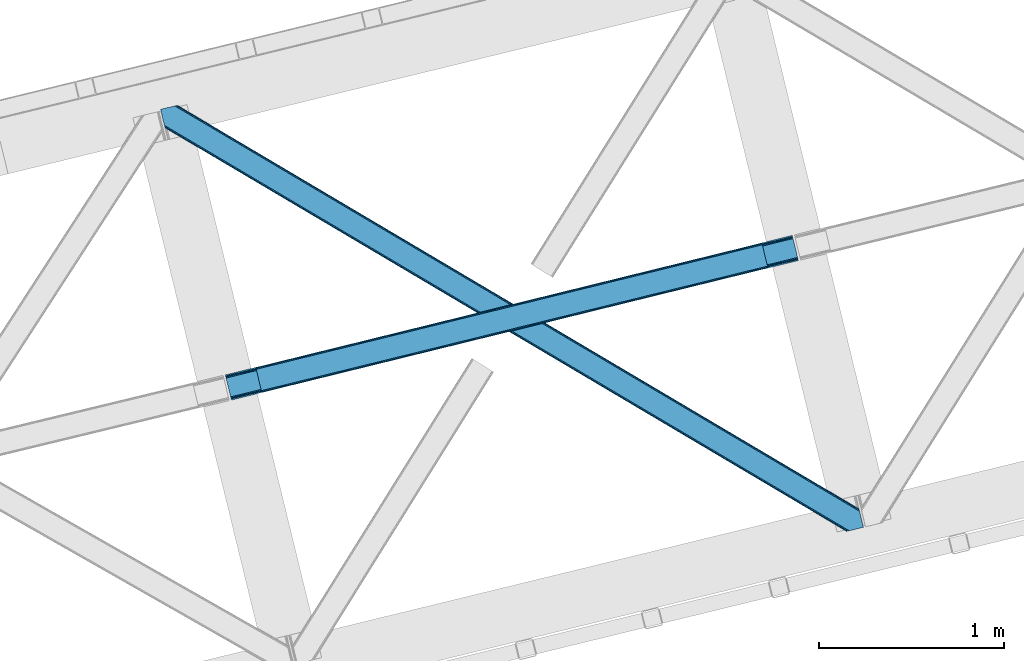
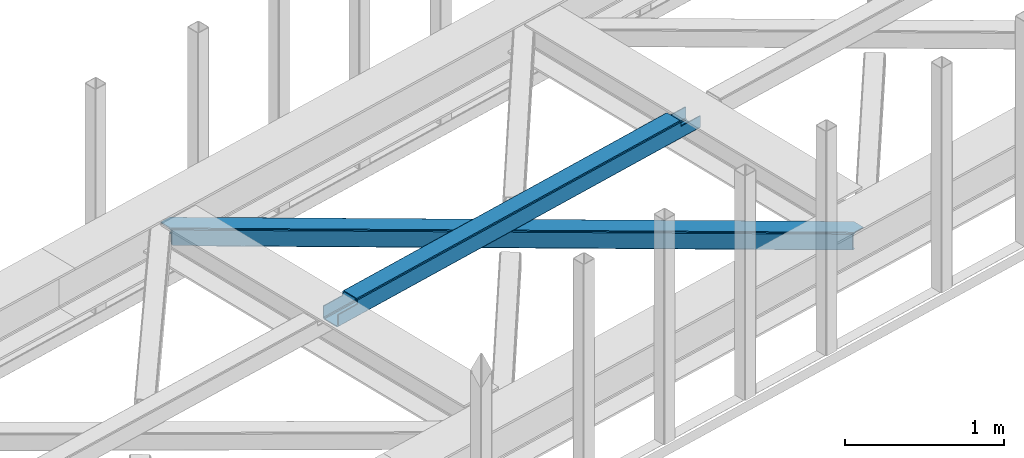
# One storey, part 39 of 67: 1 beam, 1 member.
"""IFC4 building model written with IfcOpenShell, lengths in millimetres."""

from ifc_helpers import new_model, entity, si_unit, converted_unit, derived_unit, direction, frame, origin, place, context, subcontext, project, spatial, triangles, polygons, material, type_object, element, save


model = new_model("IFC4")

# Units and contexts
model_context = context("Model", 3, precision=0.01, world=origin(), true_north=direction((6.12303176911189e-17, 1.0)))
plan_context = context("Plan", 3, precision=0.01, world=origin(), true_north=direction((6.12303176911189e-17, 1.0)))
body_context = subcontext(model_context, "Body", "Model", "MODEL_VIEW")
ifc_project = project(units=[si_unit("LENGTHUNIT", "METRE", prefix="MILLI"), si_unit("AREAUNIT", "SQUARE_METRE"), si_unit("VOLUMEUNIT", "CUBIC_METRE"), converted_unit("PLANEANGLEUNIT", "DEGREE", entity("IfcRatioMeasure", 0.0174532925199433), si_unit("PLANEANGLEUNIT", "RADIAN"), dimensions=[0, 0, 0, 0, 0, 0, 0]), si_unit("MASSUNIT", "GRAM", prefix="KILO"), derived_unit("MASSDENSITYUNIT", [(si_unit("MASSUNIT", "GRAM", prefix="KILO"), 1), (si_unit("LENGTHUNIT", "METRE"), -3)]), derived_unit("MOMENTOFINERTIAUNIT", [(si_unit("LENGTHUNIT", "METRE"), 4)]), si_unit("TIMEUNIT", "SECOND"), si_unit("FREQUENCYUNIT", "HERTZ"), si_unit("THERMODYNAMICTEMPERATUREUNIT", "DEGREE_CELSIUS"), derived_unit("THERMALTRANSMITTANCEUNIT", [(si_unit("MASSUNIT", "GRAM", prefix="KILO"), 1), (si_unit("THERMODYNAMICTEMPERATUREUNIT", "KELVIN"), -1), (si_unit("TIMEUNIT", "SECOND"), -3)]), derived_unit("VOLUMETRICFLOWRATEUNIT", [(si_unit("LENGTHUNIT", "METRE"), 3), (si_unit("TIMEUNIT", "SECOND"), -1)]), derived_unit("MASSFLOWRATEUNIT", [(si_unit("MASSUNIT", "GRAM", prefix="KILO"), 1), (si_unit("TIMEUNIT", "SECOND"), -1)]), derived_unit("ROTATIONALFREQUENCYUNIT", [(si_unit("TIMEUNIT", "SECOND"), -1)]), si_unit("ELECTRICCURRENTUNIT", "AMPERE"), si_unit("ELECTRICVOLTAGEUNIT", "VOLT"), si_unit("POWERUNIT", "WATT"), si_unit("FORCEUNIT", "NEWTON", prefix="KILO"), si_unit("ILLUMINANCEUNIT", "LUX"), si_unit("LUMINOUSFLUXUNIT", "LUMEN"), si_unit("LUMINOUSINTENSITYUNIT", "CANDELA"), derived_unit("USERDEFINED", [(si_unit("MASSUNIT", "GRAM", prefix="KILO"), -1), (si_unit("LENGTHUNIT", "METRE"), -2), (si_unit("TIMEUNIT", "SECOND"), 3), (si_unit("LUMINOUSFLUXUNIT", "LUMEN"), 1)]), derived_unit("LINEARVELOCITYUNIT", [(si_unit("LENGTHUNIT", "METRE"), 1), (si_unit("TIMEUNIT", "SECOND"), -1)]), si_unit("PRESSUREUNIT", "PASCAL"), derived_unit("USERDEFINED", [(si_unit("LENGTHUNIT", "METRE"), -2), (si_unit("MASSUNIT", "GRAM", prefix="KILO"), 1), (si_unit("TIMEUNIT", "SECOND"), -2)]), derived_unit("LINEARFORCEUNIT", [(si_unit("MASSUNIT", "GRAM", prefix="KILO"), 1), (si_unit("LENGTHUNIT", "METRE"), 1), (si_unit("TIMEUNIT", "SECOND"), -2), (si_unit("LENGTHUNIT", "METRE"), -1)]), derived_unit("PLANARFORCEUNIT", [(si_unit("MASSUNIT", "GRAM", prefix="KILO"), 1), (si_unit("LENGTHUNIT", "METRE"), 1), (si_unit("TIMEUNIT", "SECOND"), -2), (si_unit("LENGTHUNIT", "METRE"), -2)])], contexts=[model_context, plan_context])

# Site, building, storey
site_placement = place(None, origin())
site = spatial("IfcSite", under=ifc_project, at=site_placement, CompositionType="ELEMENT")
building_placement = place(site_placement, origin())
building = spatial("IfcBuilding", under=site, at=building_placement, CompositionType="ELEMENT")
storey_placement = place(building_placement, frame((0.0, 0.0, 19800.0)))
storey = spatial("IfcBuildingStorey", under=building, at=storey_placement, CompositionType="ELEMENT", Elevation=19800.0)

# Beam
ifc_material = material(Name="Metal painted (White)")
beam_type = type_object("IfcBeamType", PredefinedType="BEAM")
beam_placement = place(storey_placement, frame((-29806.6979951738, 11867.3098828586, 3967.02204271735)))
element("IfcBeam", 1, at=beam_placement, inside=storey, type_object=beam_type, material=ifc_material, ObjectType="Steel Beam", PredefinedType="BEAM", context=body_context, shape_type="Tessellation", body=[
    polygons([(195.604746583075, 47.1752169465625, 116.423738076669), (195.289267887383, 48.4694323441397, 123.120697582703), (2923.92903262095, 719.782371889898, 122.249440972472), (2924.24451131664, 718.48815649231, 115.552481466434), (194.3908605719, 52.1550459747286, 128.798103947525), (2923.03062530547, 723.467985520489, 127.926847337285), (193.04629900633, 57.6709565732295, 132.591623517896), (2921.6860637399, 728.983896118994, 131.720366907661), (191.46028050054, 64.1774167528979, 133.923727327576), (2920.10004523411, 735.490356298641, 133.052470717336), (169.909056871414, 152.588855745844, 133.923667058171), (2898.54882160498, 823.901795291585, 133.052410447936), (168.323038365632, 159.095315925473, 132.591554377688), (2896.9628030992, 830.40825547123, 131.720297767452), (166.978476800063, 164.611226523979, 128.798027287003), (2895.61824153363, 835.924166069733, 127.926770676772), (166.080069484584, 168.29684015457, 123.120615897284), (2894.71983421815, 839.609779700328, 122.24935928704), (165.764590788888, 169.591055552179, 116.423654626735), (2894.40435552246, 840.903995097923, 115.552398016495), (2892.74656908944, 847.704875020456, 100.498181174067), (2892.74656908944, 847.704875020458, 122.552393716857), (2893.06204778513, 846.410659622874, 129.249354987406), (2893.96045510062, 842.725045992283, 134.92676637713), (2895.30501666619, 837.20913539378, 138.720293467814), (2896.89103517197, 830.70267521412, 140.052406148298), (2921.75783166713, 728.689476376108, 140.052475689917), (2923.3438501729, 722.183016196485, 138.720371880237), (2924.68841173848, 716.667105597982, 134.926852309861), (2925.58681905396, 712.981491967389, 129.249445945048), (2925.90229774989, 711.687276568789, 122.55248643901), (2925.90229774965, 711.687276569775, 100.498181174067), (2924.24451131664, 718.488156492308, 100.498181174067), (2894.40435552246, 840.903995097923, 100.498181174067), (165.764590788884, 169.591055552182, 101.477957282639), (195.60474658307, 47.1752169465668, 101.477957282639), (197.262533018061, 40.37433701599, 101.477957282639), (197.262533016081, 40.3743370240292, 123.423743049245), (196.947054320385, 41.6685524216237, 130.120702555279), (196.048647004907, 45.354166052217, 135.798108920101), (194.704085439337, 50.8700766507178, 139.591628490473), (193.118066933551, 57.3765368303668, 140.923732300152), (168.251270438398, 159.389735668379, 140.923662758538), (166.665251932617, 165.896195848024, 139.59155007805), (165.320690367043, 171.412106446525, 135.798022987369), (164.422283051569, 175.097720077118, 130.120611597646), (164.106804355869, 176.391935474715, 123.423650327093), (164.106804355873, 176.391935474715, 101.477957282639), (3088.35131567249, 758.862493425842, 99.4981811740719), (3088.35131567249, 758.862493425842, 24.5000776734212), (31.4979422272015, 6.80088001302851, 25.4761331214731), (31.4979422272015, 6.80088001302851, 100.477957282644), (194.633700403446, 46.9363155445932, 100.477957282639), (1.65778643301973, 129.216718618645, 25.476049671535), (3058.5111598783, 881.278332031454, 24.499994223483), (3058.51115987832, 881.278332031454, 99.4981811740719), (2895.37540170208, 841.142896499894, 99.4981811740675), (1.65778643301539, 129.216718618643, 100.477957282639), (3090.00910210416, 752.061613508751, 17.5000819730594), (3090.00910210555, 752.061613503148, 99.4981811740762), (2926.87334392953, 711.9261779707, 99.4981811740675), (33.1557286742552, 3.25379915011581e-08, 100.477957282644), (33.1557286629934, 7.91814102285571e-08, 18.4761374211026), (3056.8533734453, 888.07921195399, 99.4981811740719), (3056.85337344529, 888.07921195399, 17.4999892509068), (4.33146851719357e-12, 136.017598541181, 18.4760446989587), (4.33146851719357e-12, 136.017598541179, 100.477957282639), (163.135758176248, 176.153034072741, 100.477957282635), (2925.21555749626, 718.727057894282, 99.4981811740719), (2893.71761526907, 847.943776422432, 99.4981811740719), (3058.826638574, 879.984116633862, 17.8030347174491), (3059.72504588947, 876.298503003269, 12.1256283526317), (3061.06960745504, 870.782592404766, 8.33210878225564), (3062.65562596083, 864.276132225121, 7.00000497257624), (3084.20684958996, 775.864693232179, 7.00006524197628), (3085.79286809575, 769.358233052533, 8.33217792246421), (3087.13742966132, 763.842322454027, 12.1257050131446), (3088.03583697679, 760.156708823439, 17.8031164028683), (3089.69362340981, 753.355828900884, 10.8031207025108), (3088.79521609433, 757.041442531473, 5.12570931278704), (3087.45065452876, 762.557353129978, 1.33218222210669), (3085.86463602297, 769.063813309644, 6.95416144253613e-05), (3060.99783952781, 871.077012147657, 4.33146851719357e-12), (3059.41182102204, 877.583472327284, 1.33210380968372), (3058.06725945647, 883.099382925789, 5.12562338005977), (3057.16885214099, 886.784996556382, 10.8030297448772), (196.291486836457, 40.1354356220577, 100.477957282644), (164.793544609264, 169.352154150206, 100.477957282639), (27.353476144676, 23.8030798193683, 7.97612069002819), (28.9394946504662, 17.296619639702, 9.30823337052045), (30.2840562160316, 11.780709041199, 13.1017604612008), (31.1824635315145, 8.09509541061007, 18.7791718509245), (1.97326512871545, 127.922503221042, 18.7790901655053), (2.87167244418966, 124.236889590447, 13.1016838006879), (4.21623400976372, 118.720978991944, 9.30816423030755), (5.80225251554089, 112.214518812312, 7.97606042062815), (0.31547869569572, 134.723383143586, 11.7790851929161), (1.21388601117427, 131.037769512995, 6.10167882810301), (2.55844757674399, 125.521858914492, 2.3081592577313), (4.14446608252982, 119.015398734848, 0.976055448051909), (29.0112625776828, 17.002199896835, 0.976124989666334), (30.5972810834643, 10.4957397171882, 2.30823767015427), (31.9418426490383, 4.97982911868517, 6.10176476083461), (32.8402499645125, 1.29421548809192, 11.7791761505583)], [[[1, 2, 3, 4]], [[2, 5, 6, 3]], [[5, 7, 8, 6]], [[7, 9, 10, 8]], [[11, 12, 10, 9]], [[11, 13, 14, 12]], [[13, 15, 16, 14]], [[15, 17, 18, 16]], [[17, 19, 20, 18]], [[21, 22, 23, 24, 25, 26, 27, 28, 29, 30, 31, 32, 33, 4, 3, 6, 8, 10, 12, 14, 16, 18, 20, 34]], [[35, 19, 17, 15, 13, 11, 9, 7, 5, 2, 1, 36, 37, 38, 39, 40, 41, 42, 43, 44, 45, 46, 47, 48]], [[42, 41, 28, 27]], [[41, 40, 29, 28]], [[40, 39, 30, 29]], [[39, 38, 31, 30]], [[27, 26, 43, 42]], [[47, 46, 23, 22]], [[46, 45, 24, 23]], [[45, 44, 25, 24]], [[44, 43, 26, 25]], [[33, 49, 50, 51, 52, 53, 1, 4]], [[54, 55, 56, 57, 20, 19, 35, 58]], [[59, 60, 61, 31, 38, 37, 62, 63]], [[64, 65, 66, 67, 68, 47, 22, 21]], [[61, 60, 49, 69]], [[64, 70, 57, 56]], [[65, 64, 56, 55, 71, 72, 73, 74, 75, 76, 77, 78, 50, 49, 60, 59, 79, 80, 81, 82, 83, 84, 85, 86]], [[87, 53, 52, 62]], [[67, 58, 88, 68]], [[89, 90, 76, 75]], [[90, 91, 77, 76]], [[91, 92, 78, 77]], [[92, 51, 50, 78]], [[54, 93, 71, 55]], [[93, 94, 72, 71]], [[94, 95, 73, 72]], [[95, 96, 74, 73]], [[89, 75, 74, 96]], [[66, 97, 98, 99, 100, 101, 102, 103, 104, 63, 62, 52, 51, 92, 91, 90, 89, 96, 95, 94, 93, 54, 58, 67]], [[63, 104, 79, 59]], [[104, 103, 80, 79]], [[103, 102, 81, 80]], [[102, 101, 82, 81]], [[100, 99, 84, 83]], [[99, 98, 85, 84]], [[98, 97, 86, 85]], [[97, 66, 65, 86]], [[83, 82, 101, 100]]], closed=False),
])

# Member
member_type = type_object("IfcMemberType", PredefinedType="BRACE")
member_placement = place(storey_placement, frame((-30155.6011962891, 11159.1828094482, 3822.99993896484)))
element("IfcMember", 2, at=member_placement, inside=storey, type_object=member_type, ObjectType="Steel Horizontal Brace", PredefinedType="BRACE", context=body_context, shape_type="Tessellation", body=[
    triangles([(3167.12993774414, 476.930191040039, 17.5012573242202), (3764.84926757812, 123.064581298828, 122.499499511719), (3764.84926757812, 123.064581298828, 17.5012573242202), (2547.33753662109, 843.86244506836, 17.5012573242202), (1927.54513549805, 1210.79469909668, 17.5012573242202), (91.5037170410142, 2297.77602539063, 122.499499511719), (687.960333251951, 1944.65804443359, 17.5012573242202), (91.5037170410142, 2297.77602539063, 17.5012573242202), (1307.752734375, 1577.726953125, 17.5012573242202), (3770.64426269531, 99.2974273681648, 140.00075683594), (3768.42579345703, 108.393383789062, 138.668280029298), (76.4813781738267, 2294.11345825195, 138.668280029298), (67.1726440429666, 2291.8438293457, 140.00075683594), (3766.5468383789, 116.103378295898, 134.87548828125), (84.376245117186, 2296.03775939941, 134.87548828125), (3765.29110107422, 121.255389404298, 129.196765136719), (89.6526672363252, 2297.32372741699, 129.196765136719), (3722.24256591797, 5.93103332519604, 140.00075683594), (18.7686218261697, 2198.47743530274, 140.00075683594), (3789.41055908203, 22.3044525146488, 140.00075683594), (0.0, 2275.47041015625, 140.00075683594), (3697.91149291992, 0.0, 122.499499511719), (3699.76254272461, 0.451135253906614, 129.196765136719), (24.1217834472627, 2176.5194732666, 129.196765136719), (24.5636169433565, 2174.71028137207, 122.499499511719), (3705.0366394043, 1.73710327148365, 134.87548828125), (22.8660461425752, 2181.671484375, 134.87548828125), (3712.93150634766, 3.66140441894458, 138.668280029298), (20.9870910644531, 2189.38147888184, 138.668280029298), (1862.08634033203, 1086.85342712402, 17.5012573242202), (2481.94152832031, 719.882803344726, 17.5012573242202), (3101.79904174805, 352.91217956543, 17.5012573242202), (3697.91149291992, 0.0, 17.5012573242202), (1242.22882690429, 1453.82405090332, 17.5012573242202), (622.37131347656, 1820.79467468262, 17.5012573242202), (24.5636169433565, 2174.71028137207, 17.5012573242202), (74.6442810058579, 2293.66581115723, 127.873590087893), (66.7494140624985, 2291.74151000977, 131.668707275392), (79.9183776855461, 2294.9517791748, 122.197192382813), (57.4383544921875, 2289.47188110352, 133.001184082033), (0.0, 2275.47041015625, 133.001184082033), (81.771752929686, 2295.40291442871, 115.499926757813), (81.771752929686, 2295.40291442871, 24.5008300781265), (79.9183776855461, 2294.9517791748, 17.8035644531265), (89.5643005371094, 2297.30279846191, 10.8156188964858), (89.4712829589844, 2297.27954406738, 10.4993591308594), (74.1164062499993, 2293.53674926758, 12.4271484375022), (72.0374633789033, 2293.03096618652, 10.4993591308594), (1922.1942993164, 1205.8275604248, 24.5008300781265), (3767.16773071289, 113.558184814454, 115.499926757813), (2545.11209106445, 837.045419311524, 24.5008300781265), (3168.0298828125, 468.263278198243, 24.5008300781265), (3767.16773071289, 113.558184814454, 24.5008300781265), (1299.27883300781, 1574.60853881836, 24.5008300781265), (676.361041259763, 1943.39067993164, 24.5008300781265), (3767.60956420898, 111.748992919922, 122.197192382813), (3768.86530151367, 106.596981811523, 127.873590087893), (3770.7442565918, 98.8869873046879, 131.668707275392), (3772.96040039062, 89.7910308837891, 133.001184082033), (3767.6979309082, 111.385061645507, 17.8686767578147), (3767.80490112305, 110.943228149414, 16.5199218750022), (3764.85856933594, 123.027374267578, 16.5199218750022), (3789.41055908203, 22.3044525146488, 133.001184082033), (3731.97685546875, 8.30414428710901, 133.001184082033), (16.4524841308594, 2207.98383178711, 133.001184082033), (162.741229248044, 2253.90428466797, 10.4993591308594), (166.892138671872, 2236.87509155273, 10.4993591308594), (3722.66579589844, 6.03451538085938, 131.668707275392), (18.6686279296846, 2198.88903808594, 131.668707275392), (3714.77092895508, 4.11021423339844, 127.873590087893), (20.5475830078103, 2191.17788085938, 127.873590087893), (3709.49683227539, 2.82424621581958, 122.197192382813), (21.8033203124978, 2186.02586975098, 122.197192382813), (3707.64345703125, 2.3719482421875, 115.499926757813), (22.2451538085916, 2184.21667785645, 115.499926757813), (3114.18665771484, 353.712130737305, 24.5008300781265), (3707.64345703125, 2.3719482421875, 24.5008300781265), (2491.12236328125, 722.583801269531, 24.5008300781265), (1868.05341796875, 1091.45430908203, 24.5008300781265), (621.920178222656, 1829.19532470703, 24.5008300781265), (22.2451538085916, 2184.21667785645, 24.5008300781265), (1244.9867980957, 1460.32481689453, 24.5008300781265), (3709.49683227539, 2.82424621581958, 17.8035644531265), (3700.13693847656, 0.541827392578853, 10.8691040039084), (3700.58807373047, 0.65228576660229, 9.52034912109593), (3714.77092895508, 4.11021423339844, 12.1248413085959), (3719.39622802734, 5.23688964843677, 9.52034912109593), (21.7823913574211, 2186.11191101074, 17.817517089843), (21.7614624023408, 2186.20144042969, 17.5012573242202), (32.1398986816384, 2171.84650268555, 10.8179443359368), (28.3494323730447, 2188.73965759277, 10.4993591308594), (27.0146301269524, 2187.35137023926, 12.1248413085959), (32.5003417968728, 2171.71046447754, 10.4993591308594), (203.968945312499, 2084.76809692383, 10.4993591308594), (208.119854736327, 2067.74006652832, 10.4993591308594), (164.099285888671, 2252.54739074707, 9.49942016601563), (168.587384033202, 2234.14502563477, 9.49942016601563), (168.16880493164, 2234.81707763672, 9.74591674804833), (163.771398925779, 2252.87527770996, 9.74126586914281), (167.738598632812, 2235.51005859375, 9.9993896484375), (163.420257568359, 2253.22641906738, 9.9993896484375), (167.306066894529, 2236.20187683106, 10.2528625488303), (163.066790771481, 2253.5775604248, 10.2598388671868), (209.166302490234, 2067.67146606445, 9.49942016601563), (209.136071777342, 2067.46682739258, 9.88311767578125), (204.682855224608, 2085.44363708496, 9.8528869628899), (208.803533935545, 2067.5551940918, 10.0831054687515), (204.685180664063, 2084.81111755371, 10.2063537597678), (208.45006713867, 2067.65053710938, 10.2993713378928), (204.327062988279, 2084.79018859863, 10.3528564453118), (204.680529785153, 2086.07499389648, 9.49942016601563), (3763.57725219726, 109.725860595703, 12.1248413085959), (3758.57058105469, 124.97144165039, 10.8714294433594), (3757.06834716797, 125.43536682129, 9.52034912109593), (3761.54714355469, 107.063232421875, 9.52034912109593), (3585.92763061524, 211.034793090821, 9.52034912109593), (3581.44883422851, 229.405764770509, 9.52034912109593), (3585.50905151367, 211.134786987304, 9.44360961914208), (3581.04885864258, 229.553430175782, 9.37384643554833), (3580.64888305664, 229.701095581055, 9.22734375000073), (3580.53958740234, 229.532501220703, 8.87387695312646), (3585.46021728516, 210.476687622071, 9.13897705078125), (3580.43029174805, 229.365069580079, 8.52041015625218), (3585.40673217773, 209.805798339843, 8.82736816406396), (3585.35789794922, 209.14769897461, 8.52041015625218), (3164.51846923828, 472.519995117187, 5.12526855468968), (3581.30465698242, 225.771102905273, 5.12526855468968), (3166.45090942383, 475.783749389648, 10.8039916992202), (687.281304931639, 1943.5116027832, 10.8039916992202), (685.348864746091, 1940.24784851074, 5.12526855468968), (165.157360839843, 2248.2150970459, 5.12526855468968), (682.456018066405, 1935.36210021973, 1.33247680664135), (167.036315917969, 2240.50510253906, 1.33247680664135), (679.046923828122, 1929.59966125488, 0.0), (169.252459716794, 2231.41030883789, 0.0), (3583.18361206055, 218.061108398437, 1.33247680664135), (3585.40208129883, 208.966314697265, 0.0), (3158.21420288086, 461.870645141602, 0.0), (3161.62562255859, 467.634246826172, 1.33247680664135), (2546.65850830078, 842.716003417969, 10.8039916992202), (1926.86610717774, 1209.64825744629, 10.8039916992202), (1307.07370605469, 1576.58051147461, 10.8039916992202), (2544.72606811523, 839.452249145508, 5.12526855468968), (1924.93366699219, 1206.3833404541, 5.12526855468968), (1305.14126586914, 1573.31559448242, 5.12526855468968), (2541.83322143555, 834.566500854493, 1.33247680664135), (1922.0408203125, 1201.49875488281, 1.33247680664135), (1302.24841918945, 1568.42984619141, 1.33247680664135), (2538.42180175781, 828.802899169921, 0.0), (1918.63172607422, 1195.73515319824, 0.0), (1298.83932495117, 1562.66740722656, 0.0), (3620.16275024414, 66.3657165527347, 0.0), (3110.71477661133, 367.97056274414, 0.0), (2490.85726318359, 734.941186523438, 0.0), (1870.99974975586, 1101.91181030273, 0.0), (631.287048339844, 1835.85305786133, 0.0), (1251.14223632812, 1468.88243408203, 0.0), (204.013128662107, 2088.80971069336, 0.0), (3167.34852905274, 467.116836547852, 17.8035644531265), (3165.41608886719, 463.851919555664, 12.1248413085959), (673.749572753906, 1938.98048400879, 12.1248413085959), (675.684338378906, 1942.24423828125, 17.8035644531265), (670.859051513671, 1934.09473571777, 8.3320495605476), (169.401287841796, 2230.8022064209, 8.81806640624927), (171.570922851563, 2221.90391235351, 6.99957275390625), (3159.11182250976, 453.203732299804, 6.99957275390625), (3587.71821899414, 199.458755493164, 6.99957275390625), (3585.50905151367, 208.524481201172, 8.42274169921802), (3162.52556762695, 458.967333984376, 8.3320495605476), (667.447631835938, 1928.33229675293, 6.99957275390625), (2536.19635620117, 821.985873413087, 6.99957275390625), (2539.60777587891, 827.749475097657, 8.3320495605476), (1916.69230957031, 1196.53161621094, 8.3320495605476), (1913.27856445313, 1190.76801452637, 6.99957275390625), (1293.77451782226, 1565.31259460449, 8.3320495605476), (1290.36309814453, 1559.55015563965, 6.99957275390625), (2542.50062255859, 832.635223388672, 12.1248413085959), (1919.58515625, 1201.41620178223, 12.1248413085959), (1296.66736450195, 1570.19834289551, 12.1248413085959), (2544.43306274414, 835.898977661132, 17.8035644531265), (1921.51527099609, 1204.68111877441, 17.8035644531265), (1298.5998046875, 1573.4632598877, 17.8035644531265), (201.696990966797, 2098.31610717773, 6.99957275390625), (203.864300537109, 2089.41781311035, 8.81806640624927), (206.229272460936, 2079.71491699219, 1.33247680664135), (208.110552978513, 2072.00492248535, 5.12526855468968), (2500.03577270508, 737.642184448243, 6.99957275390625), (3123.10471801758, 368.771676635743, 6.99957275390625), (1876.96915283203, 1106.51269226074, 6.99957275390625), (3617.84428710938, 75.8721130371086, 6.99957275390625), (630.835913085935, 1844.25487060547, 6.99957275390625), (1253.90253295898, 1475.38320007324, 6.99957275390625), (3119.69329833984, 363.009237670898, 8.3320495605476), (3620.56505126953, 65.0402160644535, 8.90410766601781), (3620.20693359375, 66.1831695556648, 8.52041015625218), (3116.80045166015, 358.123489379883, 12.1248413085959), (3621.05571899414, 64.3216552734375, 9.1087463378899), (3621.55103759766, 63.5914672851559, 9.31571044922021), (3622.04170532227, 62.8729064941399, 9.52034912109593), (3620.05345458984, 66.8075500488285, 8.42274169921802), (624.531646728516, 1833.60552062988, 12.1248413085959), (627.424493408202, 1838.4912689209, 8.3320495605476), (622.601531982422, 1830.34176635742, 17.8035644531265), (3114.86801147461, 354.858572387695, 17.8035644531265), (2491.79906616211, 723.729080200195, 17.8035644531265), (1868.73477172852, 1092.60075073242, 17.8035644531265), (1245.66582641601, 1461.47125854492, 17.8035644531265), (2493.73150634766, 726.993997192383, 12.1248413085959), (1870.66488647461, 1095.86450500488, 12.1248413085959), (1247.59826660156, 1464.73501281738, 12.1248413085959), (2496.62435302734, 731.879745483398, 8.3320495605476), (1873.5577331543, 1100.7502532959, 8.3320495605476), (1250.49111328125, 1469.6207611084, 8.3320495605476), (3102.47807006836, 354.057458496094, 10.8039916992202), (624.98278198242, 1825.20487060547, 5.12526855468968), (623.050341796872, 1821.94111633301, 10.8039916992202), (3626.52050170898, 44.5019348144524, 9.52034912109593), (3104.41051025391, 357.322375488282, 5.12526855468968), (3624.25784912109, 49.5597656249993, 5.12526855468968), (3625.13453979492, 45.9657989501957, 8.52041015625218), (3625.82752075195, 45.2344482421868, 9.02037963867406), (3622.37889404297, 57.2709228515632, 1.33247680664135), (3107.30335693359, 362.208123779297, 1.33247680664135), (627.875628662106, 1830.09061889648, 1.33247680664135), (2487.44584350586, 729.178747558593, 1.33247680664135), (1867.58833007812, 1096.14937133789, 1.33247680664135), (1247.73081665039, 1463.11999511719, 1.33247680664135), (2484.55299682617, 724.292999267578, 5.12526855468968), (1864.69548339844, 1091.26362304687, 5.12526855468968), (1244.84029541015, 1458.23424682617, 5.12526855468968), (2482.62055664062, 721.029244995118, 10.8039916992202), (1862.76304321289, 1087.99870605469, 10.8039916992202), (1242.90552978516, 1454.97049255371, 10.8039916992202)], [[1, 2, 3], [2, 1, 4], [2, 5, 6], [5, 2, 4], [7, 8, 6], [9, 6, 5], [6, 9, 7], [10, 11, 12], [12, 13, 10], [11, 14, 15], [15, 12, 11], [14, 16, 17], [17, 15, 14], [16, 2, 6], [6, 17, 16], [18, 10, 19], [18, 20, 10], [13, 19, 10], [21, 19, 13], [22, 23, 24], [24, 25, 22], [23, 26, 27], [27, 24, 23], [26, 28, 29], [29, 27, 26], [28, 18, 19], [19, 29, 28], [30, 22, 25], [22, 31, 32], [30, 31, 22], [32, 33, 22], [34, 25, 35], [25, 34, 30], [36, 35, 25], [37, 38, 12], [15, 37, 12], [15, 17, 39], [37, 15, 39], [39, 17, 6], [38, 13, 12], [21, 40, 41], [21, 13, 40], [38, 40, 13], [39, 6, 42], [43, 8, 44], [6, 43, 42], [8, 45, 44], [6, 8, 43], [46, 44, 45], [46, 47, 44], [46, 48, 47], [49, 50, 42], [50, 51, 52], [49, 51, 50], [52, 53, 50], [54, 42, 55], [42, 54, 49], [43, 55, 42], [50, 56, 42], [39, 42, 56], [56, 57, 39], [37, 39, 57], [57, 58, 37], [38, 37, 58], [58, 59, 38], [40, 38, 59], [57, 14, 11], [59, 58, 10], [58, 57, 11], [60, 61, 62], [63, 59, 20], [10, 20, 59], [58, 11, 10], [60, 3, 53], [2, 50, 53], [53, 3, 2], [60, 62, 3], [2, 56, 50], [56, 14, 57], [14, 56, 16], [2, 16, 56], [59, 64, 65], [64, 59, 63], [65, 40, 59], [41, 40, 65], [66, 67, 46], [48, 46, 67], [64, 68, 65], [69, 65, 68], [68, 70, 69], [71, 69, 70], [70, 72, 71], [73, 71, 72], [72, 74, 73], [75, 73, 74], [76, 74, 77], [74, 76, 78], [74, 79, 75], [79, 74, 78], [80, 81, 75], [82, 75, 79], [75, 82, 80], [70, 68, 28], [26, 70, 28], [26, 23, 72], [70, 26, 72], [72, 23, 22], [68, 18, 28], [20, 64, 63], [20, 18, 64], [68, 64, 18], [72, 22, 74], [77, 33, 83], [22, 77, 74], [33, 84, 83], [22, 33, 77], [85, 83, 84], [86, 83, 85], [87, 86, 85], [73, 75, 25], [25, 24, 73], [27, 73, 24], [73, 27, 71], [25, 81, 36], [88, 89, 36], [36, 81, 88], [75, 81, 25], [69, 29, 19], [21, 65, 19], [41, 65, 21], [69, 71, 29], [29, 71, 27], [65, 69, 19], [90, 91, 92], [90, 93, 91], [92, 36, 90], [89, 36, 92], [94, 95, 93], [93, 91, 94], [96, 97, 98], [98, 99, 96], [99, 98, 100], [100, 101, 99], [101, 100, 102], [102, 103, 101], [103, 102, 67], [67, 66, 103], [104, 105, 106], [105, 107, 108], [108, 107, 109], [110, 109, 95], [95, 94, 110], [109, 110, 108], [108, 106, 105], [106, 111, 104], [62, 112, 113], [112, 62, 61], [112, 114, 113], [112, 115, 114], [114, 115, 116], [116, 117, 114], [118, 119, 117], [120, 119, 118], [121, 120, 122], [123, 121, 124], [124, 125, 123], [122, 124, 121], [118, 122, 120], [117, 116, 118], [1, 3, 113], [3, 62, 113], [120, 121, 126], [123, 126, 121], [123, 127, 126], [128, 113, 117], [117, 126, 128], [117, 119, 126], [120, 126, 119], [113, 114, 117], [45, 129, 66], [129, 130, 131], [131, 96, 129], [129, 99, 101], [99, 129, 96], [129, 103, 66], [103, 129, 101], [129, 45, 8], [8, 7, 129], [66, 46, 45], [130, 132, 133], [133, 131, 130], [132, 134, 135], [135, 133, 132], [136, 137, 138], [138, 139, 136], [127, 136, 139], [139, 126, 127], [113, 128, 1], [1, 128, 4], [140, 4, 128], [4, 140, 141], [141, 5, 4], [5, 141, 142], [142, 9, 5], [9, 142, 7], [129, 7, 142], [128, 126, 140], [143, 140, 126], [140, 143, 141], [144, 141, 143], [141, 144, 145], [145, 142, 141], [142, 145, 130], [130, 129, 142], [126, 139, 143], [146, 143, 139], [143, 146, 147], [147, 144, 143], [144, 147, 145], [148, 145, 147], [145, 148, 130], [132, 130, 148], [139, 138, 146], [149, 146, 138], [146, 149, 147], [150, 147, 149], [147, 150, 148], [151, 148, 150], [148, 151, 134], [134, 132, 148], [137, 152, 153], [138, 153, 154], [153, 138, 137], [149, 155, 150], [154, 149, 138], [149, 154, 155], [156, 134, 151], [150, 157, 151], [157, 150, 155], [157, 156, 151], [158, 134, 156], [135, 134, 158], [159, 160, 112], [112, 61, 159], [159, 60, 53], [161, 162, 44], [98, 163, 100], [98, 97, 163], [163, 102, 100], [163, 67, 102], [97, 164, 163], [161, 47, 67], [67, 163, 161], [47, 48, 67], [163, 164, 165], [166, 167, 168], [160, 118, 116], [116, 112, 160], [116, 115, 112], [169, 168, 125], [125, 160, 169], [124, 122, 160], [122, 118, 160], [160, 125, 124], [168, 169, 166], [165, 170, 163], [44, 47, 161], [162, 55, 43], [43, 44, 162], [53, 52, 159], [61, 60, 159], [166, 169, 171], [172, 171, 169], [171, 172, 173], [173, 174, 171], [174, 173, 175], [175, 176, 174], [176, 175, 163], [163, 170, 176], [169, 160, 172], [177, 172, 160], [172, 177, 178], [178, 173, 172], [173, 178, 175], [179, 175, 178], [175, 179, 163], [161, 163, 179], [160, 159, 180], [180, 177, 160], [177, 180, 178], [181, 178, 180], [178, 181, 182], [182, 179, 178], [179, 182, 162], [162, 161, 179], [159, 52, 51], [51, 180, 159], [180, 51, 49], [49, 181, 180], [181, 49, 54], [54, 182, 181], [182, 54, 162], [55, 162, 54], [97, 131, 133], [135, 97, 133], [165, 164, 135], [165, 135, 183], [131, 97, 96], [135, 164, 97], [183, 158, 184], [158, 185, 111], [158, 183, 135], [186, 111, 185], [158, 111, 184], [186, 104, 111], [187, 188, 166], [166, 171, 187], [171, 189, 187], [189, 171, 174], [188, 167, 166], [188, 190, 167], [170, 191, 176], [191, 170, 183], [165, 183, 170], [192, 176, 191], [174, 192, 189], [176, 192, 174], [193, 194, 195], [196, 197, 194], [196, 198, 197], [196, 199, 198], [194, 193, 196], [195, 200, 193], [86, 87, 199], [199, 196, 86], [193, 200, 190], [191, 183, 184], [201, 108, 110], [110, 94, 201], [94, 92, 201], [94, 91, 92], [202, 106, 108], [202, 111, 106], [202, 184, 111], [108, 201, 202], [203, 201, 92], [92, 89, 203], [203, 88, 81], [81, 80, 203], [89, 88, 203], [184, 202, 191], [190, 188, 193], [83, 86, 196], [196, 204, 83], [77, 83, 204], [204, 76, 77], [76, 204, 205], [205, 78, 76], [78, 205, 206], [206, 79, 78], [79, 206, 207], [207, 82, 79], [82, 207, 203], [203, 80, 82], [204, 196, 205], [208, 205, 196], [205, 208, 209], [209, 206, 205], [206, 209, 207], [210, 207, 209], [207, 210, 203], [201, 203, 210], [196, 193, 211], [211, 208, 196], [208, 211, 209], [212, 209, 211], [209, 212, 213], [213, 210, 209], [210, 213, 202], [202, 201, 210], [193, 188, 187], [187, 211, 193], [211, 187, 189], [189, 212, 211], [212, 189, 213], [192, 213, 189], [213, 192, 202], [191, 202, 192], [214, 84, 33], [35, 36, 90], [215, 105, 104], [216, 90, 95], [95, 215, 216], [95, 107, 215], [104, 186, 215], [84, 214, 217], [214, 218, 219], [219, 220, 214], [221, 217, 214], [214, 220, 221], [217, 85, 84], [222, 219, 218], [218, 223, 222], [152, 222, 223], [223, 153, 152], [156, 224, 185], [185, 158, 156], [224, 215, 186], [186, 185, 224], [90, 216, 35], [33, 32, 214], [153, 223, 225], [225, 154, 153], [154, 225, 226], [226, 155, 154], [155, 226, 227], [227, 157, 155], [157, 227, 224], [224, 156, 157], [223, 218, 225], [228, 225, 218], [225, 228, 226], [229, 226, 228], [226, 229, 227], [230, 227, 229], [227, 230, 224], [215, 224, 230], [218, 214, 231], [231, 228, 218], [228, 231, 232], [232, 229, 228], [229, 232, 233], [233, 230, 229], [230, 233, 216], [216, 215, 230], [214, 32, 31], [31, 231, 214], [231, 31, 232], [30, 232, 31], [232, 30, 233], [34, 233, 30], [233, 34, 216], [35, 216, 34], [137, 167, 190], [125, 127, 123], [137, 125, 167], [125, 136, 127], [125, 137, 136], [152, 137, 190], [195, 152, 190], [219, 195, 220], [195, 222, 152], [195, 219, 222], [220, 195, 194], [221, 194, 197], [221, 197, 198], [217, 198, 199], [87, 85, 199], [217, 199, 85]]),
])

save(model, "model.ifc")
